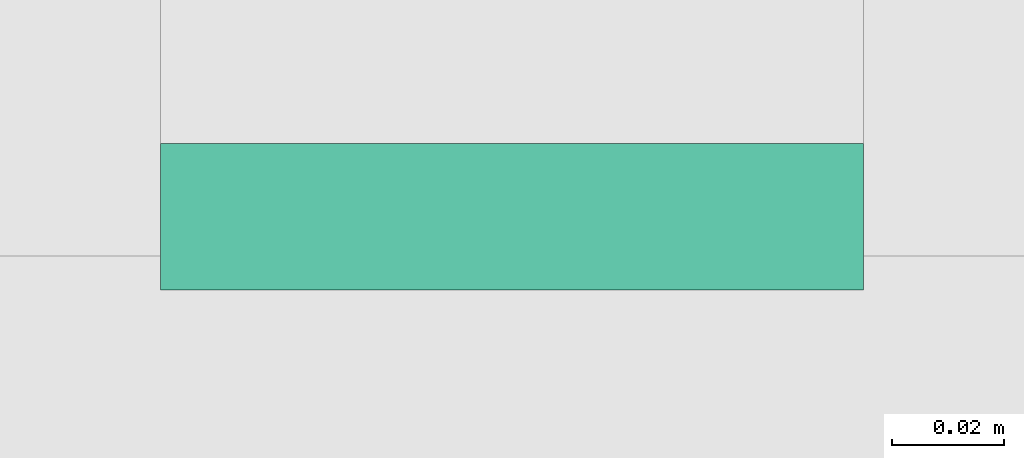
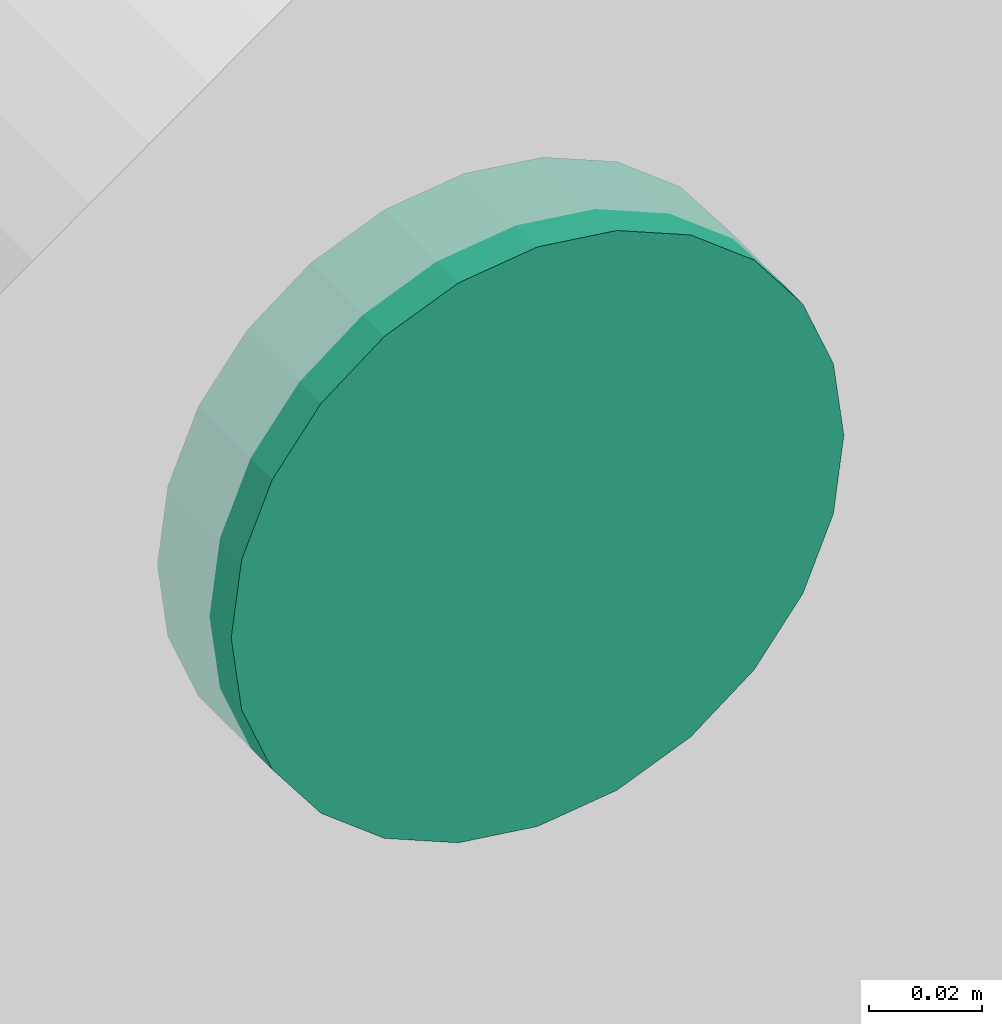
# One storey, part 147 of 337: 1 flow fitting.
"""IFC2X3 building model written with IfcOpenShell, lengths in millimetres."""

from ifc_helpers import new_model, entity, si_unit, converted_unit, derived_unit, direction, frame, origin, place, context, subcontext, project, spatial, faceted_brep, source, transform, mapped, material, type_object, type_shapes, element, save


model = new_model("IFC2X3")

# Units and contexts
model_context = context("Model", 3, precision=0.01, world=origin(), true_north=direction((6.12303176911189e-17, 1.0)))
body_context = subcontext(model_context, "Body", "Model", "MODEL_VIEW")
ifc_project = project(units=[si_unit("LENGTHUNIT", "METRE", prefix="MILLI"), si_unit("AREAUNIT", "SQUARE_METRE"), si_unit("VOLUMEUNIT", "CUBIC_METRE"), converted_unit("PLANEANGLEUNIT", "DEGREE", entity("IfcRatioMeasure", 0.0174532925199433), si_unit("PLANEANGLEUNIT", "RADIAN"), dimensions=[0, 0, 0, 0, 0, 0, 0]), si_unit("MASSUNIT", "GRAM", prefix="KILO"), derived_unit("MASSDENSITYUNIT", [(si_unit("MASSUNIT", "GRAM", prefix="KILO"), 1), (si_unit("LENGTHUNIT", "METRE"), -3)]), derived_unit("MOMENTOFINERTIAUNIT", [(si_unit("LENGTHUNIT", "METRE"), 4)]), si_unit("TIMEUNIT", "SECOND"), si_unit("FREQUENCYUNIT", "HERTZ"), si_unit("THERMODYNAMICTEMPERATUREUNIT", "DEGREE_CELSIUS"), derived_unit("THERMALTRANSMITTANCEUNIT", [(si_unit("MASSUNIT", "GRAM", prefix="KILO"), 1), (si_unit("THERMODYNAMICTEMPERATUREUNIT", "KELVIN"), -1), (si_unit("TIMEUNIT", "SECOND"), -3)]), derived_unit("VOLUMETRICFLOWRATEUNIT", [(si_unit("LENGTHUNIT", "METRE"), 3), (si_unit("TIMEUNIT", "SECOND"), -1)]), derived_unit("MASSFLOWRATEUNIT", [(si_unit("MASSUNIT", "GRAM", prefix="KILO"), 1), (si_unit("TIMEUNIT", "SECOND"), -1)]), derived_unit("ROTATIONALFREQUENCYUNIT", [(si_unit("TIMEUNIT", "SECOND"), -1)]), si_unit("ELECTRICCURRENTUNIT", "AMPERE"), si_unit("ELECTRICVOLTAGEUNIT", "VOLT"), si_unit("POWERUNIT", "WATT"), si_unit("FORCEUNIT", "NEWTON", prefix="KILO"), si_unit("ILLUMINANCEUNIT", "LUX"), si_unit("LUMINOUSFLUXUNIT", "LUMEN"), si_unit("LUMINOUSINTENSITYUNIT", "CANDELA"), derived_unit("USERDEFINED", [(si_unit("MASSUNIT", "GRAM", prefix="KILO"), -1), (si_unit("LENGTHUNIT", "METRE"), -2), (si_unit("TIMEUNIT", "SECOND"), 3), (si_unit("LUMINOUSFLUXUNIT", "LUMEN"), 1)]), derived_unit("LINEARVELOCITYUNIT", [(si_unit("LENGTHUNIT", "METRE"), 1), (si_unit("TIMEUNIT", "SECOND"), -1)]), si_unit("PRESSUREUNIT", "PASCAL"), derived_unit("USERDEFINED", [(si_unit("LENGTHUNIT", "METRE"), -2), (si_unit("MASSUNIT", "GRAM", prefix="KILO"), 1), (si_unit("TIMEUNIT", "SECOND"), -2)]), derived_unit("LINEARFORCEUNIT", [(si_unit("MASSUNIT", "GRAM", prefix="KILO"), 1), (si_unit("LENGTHUNIT", "METRE"), 1), (si_unit("TIMEUNIT", "SECOND"), -2), (si_unit("LENGTHUNIT", "METRE"), -1)]), derived_unit("PLANARFORCEUNIT", [(si_unit("MASSUNIT", "GRAM", prefix="KILO"), 1), (si_unit("LENGTHUNIT", "METRE"), 1), (si_unit("TIMEUNIT", "SECOND"), -2), (si_unit("LENGTHUNIT", "METRE"), -2)])], contexts=[model_context])

# Site, building, storey
site_placement = place(None, origin())
site = spatial("IfcSite", under=ifc_project, at=site_placement, CompositionType="ELEMENT")
building_placement = place(site_placement, origin())
building = spatial("IfcBuilding", under=site, at=building_placement, CompositionType="ELEMENT")
storey_placement = place(building_placement, origin())
storey = spatial("IfcBuildingStorey", under=building, at=storey_placement, CompositionType="ELEMENT", Elevation=0.0)

# Flow fitting
ifc_material = material()
duct_fitting_type = type_object("IfcDuctFittingType", PredefinedType="NOTDEFINED", material=ifc_material)
shared_shape = source(origin(), body_context, "Body", "Brep", [
    faceted_brep([(20.0, 16.18, -60.37), (20.0, 31.25, -54.13), (20.0, 44.19, -44.19), (20.0, 54.13, -31.25), (20.0, 60.37, -16.18), (20.0, 62.5, 0.0), (20.0, 60.37, 16.18), (20.0, 54.13, 31.25), (20.0, 44.19, 44.19), (20.0, 31.25, 54.13), (20.0, 16.18, 60.37), (20.0, 0.0, 62.5), (20.0, -16.18, 60.37), (20.0, -31.25, 54.13), (20.0, -44.19, 44.19), (20.0, -54.13, 31.25), (20.0, -60.37, 16.18), (20.0, -62.5, 0.0), (20.0, -60.37, -16.18), (20.0, -54.13, -31.25), (20.0, -44.19, -44.19), (20.0, -31.25, -54.13), (20.0, -16.18, -60.37), (20.0, 0.0, -62.5), (0.0, 0.0, 62.5), (0.0, 16.18, 60.37), (-6.1, 16.18, 60.37), (-6.1, 0.0, 62.5), (0.0, 31.25, 54.13), (-6.1, 31.25, 54.13), (0.0, 44.19, 44.19), (-6.1, 44.19, 44.19), (0.0, 54.13, 31.25), (0.0, 60.37, 16.18), (-6.1, 60.37, 16.18), (-6.1, 54.13, 31.25), (0.0, 62.5, 0.0), (-6.1, 62.5, 0.0), (0.0, 60.37, -16.18), (-6.1, 60.37, -16.18), (0.0, 54.13, -31.25), (-6.1, 54.13, -31.25), (0.0, 44.19, -44.19), (-6.1, 44.19, -44.19), (0.0, 31.25, -54.13), (0.0, 16.18, -60.37), (-6.1, 16.18, -60.37), (-6.1, 31.25, -54.13), (0.0, 0.0, -62.5), (-6.1, 0.0, -62.5), (0.0, -16.18, -60.37), (-6.1, -16.18, -60.37), (0.0, -31.25, -54.13), (-6.1, -31.25, -54.13), (0.0, -44.19, -44.19), (-6.1, -44.19, -44.19), (0.0, -54.13, -31.25), (0.0, -60.37, -16.18), (-6.1, -60.37, -16.18), (-6.1, -54.13, -31.25), (0.0, -62.5, 0.0), (-6.1, -62.5, 0.0), (0.0, -60.37, 16.18), (-6.1, -60.37, 16.18), (0.0, -54.13, 31.25), (-6.1, -54.13, 31.25), (0.0, -44.19, 44.19), (-6.1, -44.19, 44.19), (0.0, -31.25, 54.13), (0.0, -16.18, 60.37), (-6.1, -16.18, 60.37), (-6.1, -31.25, 54.13)], [[[0, 1, 2, 3, 4, 5, 6, 7, 8, 9, 10, 11, 12, 13, 14, 15, 16, 17, 18, 19, 20, 21, 22, 23]], [[24, 11, 10, 25, 26, 27]], [[25, 10, 9, 28, 29, 26]], [[28, 9, 8, 30, 31, 29]], [[32, 7, 6, 33, 34, 35]], [[33, 6, 5, 36, 37, 34]], [[30, 8, 7, 32, 35, 31]], [[36, 5, 4, 38, 39, 37]], [[38, 4, 3, 40, 41, 39]], [[40, 3, 2, 42, 43, 41]], [[44, 1, 0, 45, 46, 47]], [[45, 0, 23, 48, 49, 46]], [[42, 2, 1, 44, 47, 43]], [[48, 23, 22, 50, 51, 49]], [[50, 22, 21, 52, 53, 51]], [[52, 21, 20, 54, 55, 53]], [[56, 19, 18, 57, 58, 59]], [[57, 18, 17, 60, 61, 58]], [[54, 20, 19, 56, 59, 55]], [[60, 17, 16, 62, 63, 61]], [[62, 16, 15, 64, 65, 63]], [[64, 15, 14, 66, 67, 65]], [[68, 13, 12, 69, 70, 71]], [[69, 12, 11, 24, 27, 70]], [[66, 14, 13, 68, 71, 67]], [[49, 51, 53, 55, 59, 58, 61, 63, 65, 67, 71, 70, 27, 26, 29, 31, 35, 34, 37, 39, 41, 43, 47, 46]]]),
])
type_shapes(duct_fitting_type, [shared_shape])
flow_fitting_placement = place(storey_placement, frame((32072.6, 14626.58, 3300.0), z_axis=(0.0, 0.0, -1.0), x_axis=(0.0, 1.0, 0.0)))
element("IfcFlowFitting", 1, at=flow_fitting_placement, inside=storey, type_object=duct_fitting_type, material=ifc_material, context=body_context, shape_type="MappedRepresentation", body=[
    mapped(shared_shape, transform((0.0, 0.0, 0.0), scale=1.0)),
])

save(model, "model.ifc")
